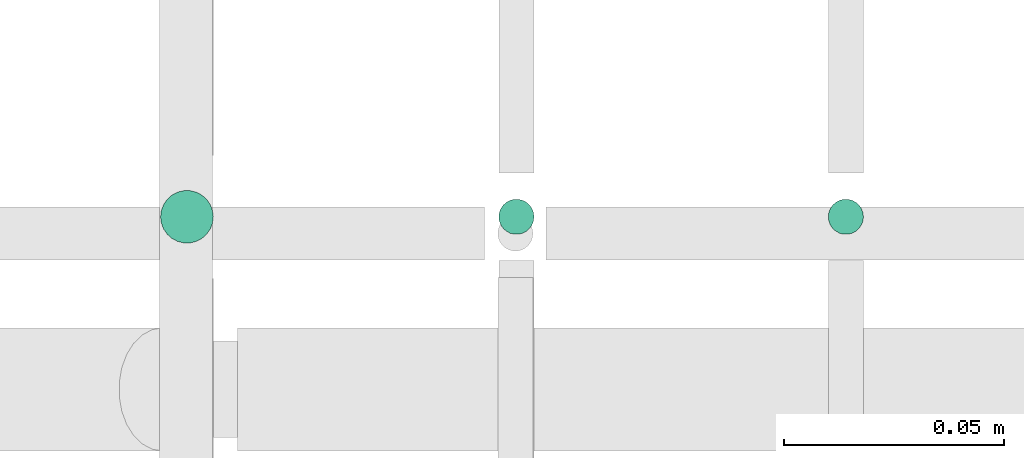
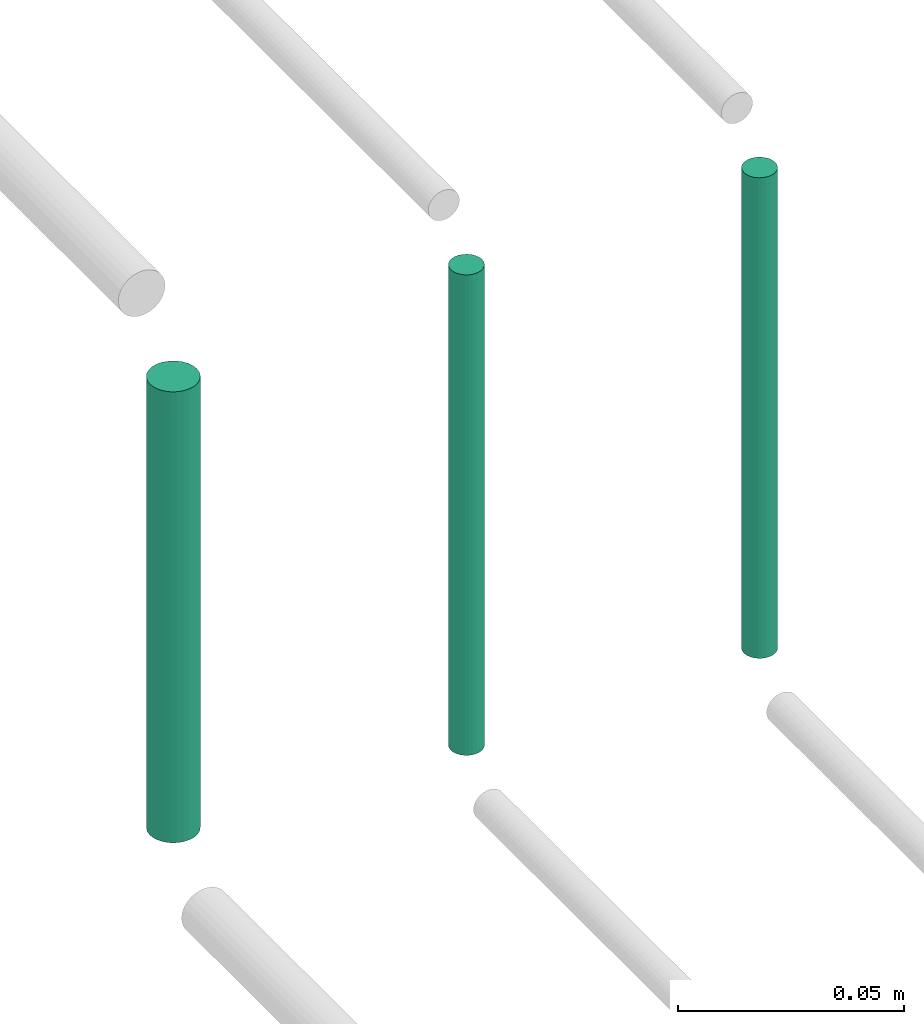
# One storey, part 153 of 331: 3 flow segments.
"""IFC2X3 building model written with IfcOpenShell, lengths in millimetres."""

from ifc_helpers import new_model, entity, si_unit, converted_unit, derived_unit, direction, frame, origin, origin_2d_with_axis, place, context, subcontext, project, spatial, circle, extrude, type_object, element, save


model = new_model("IFC2X3")

# Units and contexts
model_context = context("Model", 3, precision=0.01, world=origin(), true_north=direction((6.12303176911189e-17, 1.0)))
body_context = subcontext(model_context, "Body", "Model", "MODEL_VIEW")
ifc_project = project(units=[si_unit("LENGTHUNIT", "METRE", prefix="MILLI"), si_unit("AREAUNIT", "SQUARE_METRE"), si_unit("VOLUMEUNIT", "CUBIC_METRE"), converted_unit("PLANEANGLEUNIT", "DEGREE", entity("IfcRatioMeasure", 0.0174532925199433), si_unit("PLANEANGLEUNIT", "RADIAN"), dimensions=[0, 0, 0, 0, 0, 0, 0]), si_unit("MASSUNIT", "GRAM", prefix="KILO"), derived_unit("MASSDENSITYUNIT", [(si_unit("MASSUNIT", "GRAM", prefix="KILO"), 1), (si_unit("LENGTHUNIT", "METRE"), -3)]), derived_unit("MOMENTOFINERTIAUNIT", [(si_unit("LENGTHUNIT", "METRE"), 4)]), si_unit("TIMEUNIT", "SECOND"), si_unit("FREQUENCYUNIT", "HERTZ"), si_unit("THERMODYNAMICTEMPERATUREUNIT", "DEGREE_CELSIUS"), derived_unit("THERMALTRANSMITTANCEUNIT", [(si_unit("MASSUNIT", "GRAM", prefix="KILO"), 1), (si_unit("THERMODYNAMICTEMPERATUREUNIT", "KELVIN"), -1), (si_unit("TIMEUNIT", "SECOND"), -3)]), derived_unit("VOLUMETRICFLOWRATEUNIT", [(si_unit("LENGTHUNIT", "METRE"), 3), (si_unit("TIMEUNIT", "SECOND"), -1)]), derived_unit("MASSFLOWRATEUNIT", [(si_unit("MASSUNIT", "GRAM", prefix="KILO"), 1), (si_unit("TIMEUNIT", "SECOND"), -1)]), derived_unit("ROTATIONALFREQUENCYUNIT", [(si_unit("TIMEUNIT", "SECOND"), -1)]), si_unit("ELECTRICCURRENTUNIT", "AMPERE"), si_unit("ELECTRICVOLTAGEUNIT", "VOLT"), si_unit("POWERUNIT", "WATT"), si_unit("FORCEUNIT", "NEWTON", prefix="KILO"), si_unit("ILLUMINANCEUNIT", "LUX"), si_unit("LUMINOUSFLUXUNIT", "LUMEN"), si_unit("LUMINOUSINTENSITYUNIT", "CANDELA"), derived_unit("USERDEFINED", [(si_unit("MASSUNIT", "GRAM", prefix="KILO"), -1), (si_unit("LENGTHUNIT", "METRE"), -2), (si_unit("TIMEUNIT", "SECOND"), 3), (si_unit("LUMINOUSFLUXUNIT", "LUMEN"), 1)]), derived_unit("LINEARVELOCITYUNIT", [(si_unit("LENGTHUNIT", "METRE"), 1), (si_unit("TIMEUNIT", "SECOND"), -1)]), si_unit("PRESSUREUNIT", "PASCAL"), derived_unit("USERDEFINED", [(si_unit("LENGTHUNIT", "METRE"), -2), (si_unit("MASSUNIT", "GRAM", prefix="KILO"), 1), (si_unit("TIMEUNIT", "SECOND"), -2)]), derived_unit("LINEARFORCEUNIT", [(si_unit("MASSUNIT", "GRAM", prefix="KILO"), 1), (si_unit("LENGTHUNIT", "METRE"), 1), (si_unit("TIMEUNIT", "SECOND"), -2), (si_unit("LENGTHUNIT", "METRE"), -1)]), derived_unit("PLANARFORCEUNIT", [(si_unit("MASSUNIT", "GRAM", prefix="KILO"), 1), (si_unit("LENGTHUNIT", "METRE"), 1), (si_unit("TIMEUNIT", "SECOND"), -2), (si_unit("LENGTHUNIT", "METRE"), -2)])], contexts=[model_context])

# Site, building, storey
site_placement = place(None, frame((0.0, -0.00077364408347762, 0.0)))
site = spatial("IfcSite", under=ifc_project, at=site_placement, CompositionType="ELEMENT")
building_placement = place(site_placement, origin())
building = spatial("IfcBuilding", under=site, at=building_placement, CompositionType="ELEMENT")
storey_placement = place(building_placement, origin())
storey = spatial("IfcBuildingStorey", under=building, at=storey_placement, CompositionType="ELEMENT", Elevation=0.0)

# Flow segments
pipe_segment_type = type_object("IfcPipeSegmentType", PredefinedType="NOTDEFINED")
flow_segment_1_placement = place(storey_placement, frame((35465.7427281405, 8229.21546224645, 18660.0)))
element("IfcFlowSegment", 1, at=flow_segment_1_placement, inside=storey, type_object=pipe_segment_type, context=body_context, shape_type="SweptSolid", body=[
    extrude(circle(Radius=4.0, at=origin_2d_with_axis()), frame((5.59527223591499, 5.59527223591607, 0.0), z_axis=(0.0, 0.0, 1.0), x_axis=(-1.0, 0.0, 0.0)), (0.0, 0.0, 1.0), 130.000000000022),
])
flow_segment_2_placement = place(storey_placement, frame((35388.7427281405, 8227.21546224645, 18664.0)))
element("IfcFlowSegment", 2, at=flow_segment_2_placement, inside=storey, type_object=pipe_segment_type, context=body_context, shape_type="SweptSolid", body=[
    extrude(circle(Radius=6.0, at=origin_2d_with_axis()), frame((7.59527223591454, 7.59527223591562, 0.0), z_axis=(0.0, 0.0, 1.0), x_axis=(-1.0, 0.0, 0.0)), (0.0, 0.0, 1.0), 122.000000000018),
])
flow_segment_3_placement = place(building_placement, frame((35540.7427281404, 8229.21546224645, 18660.0)))
element("IfcFlowSegment", 3, at=flow_segment_3_placement, inside=storey, type_object=pipe_segment_type, context=body_context, shape_type="SweptSolid", body=[
    extrude(circle(Radius=4.0, at=origin_2d_with_axis()), frame((5.59527223591499, 5.59527223591607, 0.0), z_axis=(0.0, 0.0, 1.0), x_axis=(-1.0, 0.0, 0.0)), (0.0, 0.0, 1.0), 130.000000000042),
])

save(model, "model.ifc")
